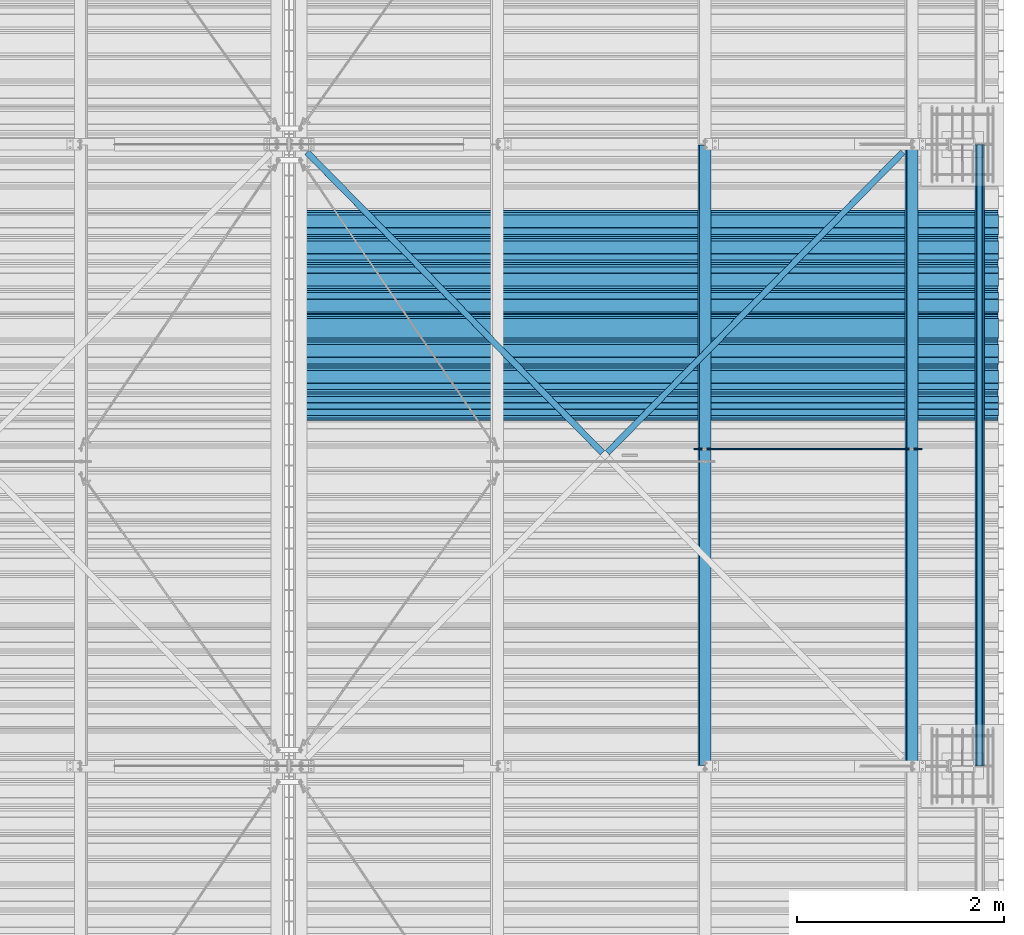
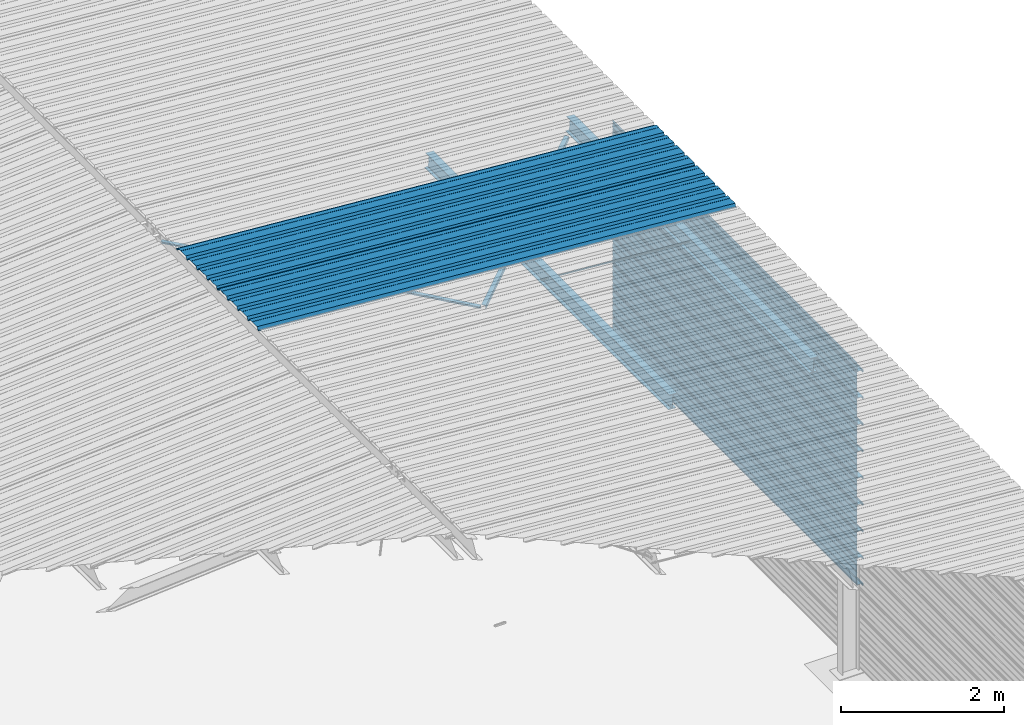
# One storey, part 13 of 70: 16 beams, 16 elements without a shape of their own.
"""IFC2X3 building model written with IfcOpenShell, lengths in millimetres."""

import ifcopenshell
import ifcopenshell.guid

model = None  # the IFC model being written
_history = None  # IfcOwnerHistory: only IFC2X3 demands one
_inside = {}  # id of a spatial element -> (the spatial element, [elements in it])
_under = {}  # id of a project, library or spatial element -> (it, [spatial elements below it])
_declared = {}  # id of a project -> (the project, [libraries it declares])
_typed = {}  # id of a type object -> (the type object, [elements of that type])
_made_of = {}  # id of a material, layer set ... -> (it, [elements and type objects made of it])


def new_model(schema):
    """Start an empty IFC model of exactly this schema.

    Asked for "IFC4X3", IfcOpenShell would pick the latest addendum, in which some entities
    have other attributes; the version numbers below select the first issue.
    IFC2X3 requires an IfcOwnerHistory on every rooted entity: one is made here for all.
    """
    global model, _history
    if schema == "IFC4X3":
        model = ifcopenshell.file(schema_version=(4, 3, 0, 0))
    else:
        model = ifcopenshell.file(schema=schema)
    _inside.clear()
    _under.clear()
    _declared.clear()
    _typed.clear()
    _made_of.clear()
    _history = None
    if model.schema == "IFC2X3":
        org = make("IfcOrganization", Name="unknown")
        user = make(
            "IfcPersonAndOrganization",
            ThePerson=make("IfcPerson", FamilyName="unknown"),
            TheOrganization=org,
        )
        app = make(
            "IfcApplication",
            ApplicationDeveloper=org,
            Version="unknown",
            ApplicationFullName="unknown",
            ApplicationIdentifier="unknown",
        )
        _history = make(
            "IfcOwnerHistory",
            OwningUser=user,
            OwningApplication=app,
            ChangeAction="ADDED",
            CreationDate=0,
        )
    return model


def make(cls, **values):
    """One entity of the class cls with the attributes given. An attribute that is None is left unset."""
    return model.create_entity(
        cls, **{name: value for name, value in values.items() if value is not None}
    )


def rooted(cls, **values):
    """An entity with a GlobalId (a new one), such as an element, a storey or a relation."""
    return make(cls, GlobalId=ifcopenshell.guid.new(), OwnerHistory=_history, **values)


def si_unit(unit_type, name, prefix=None):
    """IfcSIUnit, for example si_unit("LENGTHUNIT", "METRE", prefix="MILLI")."""
    return make("IfcSIUnit", UnitType=unit_type, Prefix=prefix, Name=name)


def assignment(units):
    """IfcUnitAssignment: the units of a project."""
    return None if units is None else make("IfcUnitAssignment", Units=units)


def point(xyz):
    """IfcCartesianPoint."""
    return None if xyz is None else make("IfcCartesianPoint", Coordinates=xyz)


def direction(xyz):
    """IfcDirection."""
    return None if xyz is None else make("IfcDirection", DirectionRatios=xyz)


def frame(location, z_axis=None, x_axis=None):
    """IfcAxis2Placement3D, a coordinate frame: its origin and axes. An axis left out is left unset."""
    return make(
        "IfcAxis2Placement3D",
        Location=point(location),
        Axis=direction(z_axis),
        RefDirection=direction(x_axis),
    )


def frame_2d(location, x_axis=None):
    """IfcAxis2Placement2D, a coordinate frame in the plane: its origin and x axis."""
    return make(
        "IfcAxis2Placement2D", Location=point(location), RefDirection=direction(x_axis)
    )


def origin_with_axes():
    """The frame at (0, 0, 0) with the z axis (0, 0, 1) and the x axis (1, 0, 0) written out."""
    return frame((0.0, 0.0, 0.0), z_axis=(0.0, 0.0, 1.0), x_axis=(1.0, 0.0, 0.0))


def origin_2d_with_axis():
    """The frame at (0, 0) in the plane with the x axis (1, 0) written out."""
    return frame_2d((0.0, 0.0), x_axis=(1.0, 0.0))


def place(relative_to, where):
    """IfcLocalPlacement: puts the frame where relative to a parent placement (None: the world)."""
    return make(
        "IfcLocalPlacement", PlacementRelTo=relative_to, RelativePlacement=where
    )


def context(
    kind, dimensions, precision=None, world=None, true_north=None, identifier=None
):
    """IfcGeometricRepresentationContext, for example the 3D "Model" context."""
    return make(
        "IfcGeometricRepresentationContext",
        ContextIdentifier=identifier,
        ContextType=kind,
        CoordinateSpaceDimension=dimensions,
        Precision=precision,
        WorldCoordinateSystem=world,
        TrueNorth=true_north,
    )


def subcontext(parent, identifier, kind, view, scale=None):
    """IfcGeometricRepresentationSubContext, for example "Body" below "Model"."""
    return make(
        "IfcGeometricRepresentationSubContext",
        ContextIdentifier=identifier,
        ContextType=kind,
        ParentContext=parent,
        TargetScale=scale,
        TargetView=view,
    )


def project(units=None, contexts=None):
    """IfcProject with its units and contexts."""
    return rooted(
        "IfcProject",
        Name="project",
        RepresentationContexts=contexts,
        UnitsInContext=assignment(units),
    )


def spatial(cls, under=None, at=None, **own):
    """A site, building, storey or space (cls), placed at a placement, below another one or the project."""
    s = rooted(cls, ObjectPlacement=at, **own)
    if under is not None:
        _under.setdefault(under.id(), (under, []))[1].append(s)
    return s


def polyline(points):
    """IfcPolyline through the points."""
    return make("IfcPolyline", Points=[point(p) for p in points])


def profile(cls, at=None, kind="AREA", **sizes):
    """A parametric profile (cls). Its sizes go by their IFC names, for example OverallWidth=200.0."""
    return make(cls, ProfileType=kind, Position=at, **sizes)


def circle(**sizes):
    """IfcCircleProfileDef."""
    return profile("IfcCircleProfileDef", **sizes)


def i_section(**sizes):
    """IfcIShapeProfileDef."""
    return profile("IfcIShapeProfileDef", **sizes)


def l_section(**sizes):
    """IfcLShapeProfileDef."""
    return profile("IfcLShapeProfileDef", **sizes)


def outline(outer, holes=None, kind="AREA"):
    """IfcArbitraryClosedProfileDef: a profile drawn as a closed curve; with holes, ...WithVoids."""
    if holes is None:
        return make("IfcArbitraryClosedProfileDef", ProfileType=kind, OuterCurve=outer)
    return make(
        "IfcArbitraryProfileDefWithVoids",
        ProfileType=kind,
        OuterCurve=outer,
        InnerCurves=holes,
    )


def extrude(swept, where, along, depth):
    """IfcExtrudedAreaSolid: the profile swept, set in the frame where, extruded along a direction by depth."""
    return make(
        "IfcExtrudedAreaSolid",
        SweptArea=swept,
        Position=where,
        ExtrudedDirection=direction(along),
        Depth=depth,
    )


def clip(a, b, op="DIFFERENCE"):
    """IfcBooleanClippingResult: the solid a cut by the half space b."""
    return make(
        "IfcBooleanClippingResult", Operator=op, FirstOperand=a, SecondOperand=b
    )


def halfspace(plane, agree):
    """IfcHalfSpaceSolid: all space on one side of the plane z = 0 of the frame plane."""
    return make(
        "IfcHalfSpaceSolid",
        BaseSurface=make("IfcPlane", Position=plane),
        AgreementFlag=agree,
    )


def shape(context_of_items, identifier, shape_type, items):
    """IfcShapeRepresentation: the items that make up one representation, for example the "Body"."""
    return make(
        "IfcShapeRepresentation",
        ContextOfItems=context_of_items,
        RepresentationIdentifier=identifier,
        RepresentationType=shape_type,
        Items=items,
    )


def material(Name=None, Category=None):
    """IfcMaterial."""
    return make("IfcMaterial", Name=Name, Category=Category)


def made_of(thing, what):
    """Note that an element or type object is made of a material, layer set ...; save() writes the relation."""
    if what is not None:
        _made_of.setdefault(what.id(), (what, []))[1].append(thing)
    return thing


def type_object(cls, material=None, **own):
    """A type object (cls), such as IfcWallType, which elements share."""
    return made_of(rooted(cls, **own), material)


def element(
    cls,
    number,
    at=None,
    inside=None,
    cuts=None,
    type_object=None,
    material=None,
    context=None,
    identifier="Body",
    shape_type=None,
    held_by="IfcProductDefinitionShape",
    body=None,
    shapes=None,
    **own,
):
    """One element of the class cls, such as IfcWall. Its Tag is "e" and its number.

    at: its placement. inside: the storey or other place that contains it. cuts: it is an
    opening in that element (IfcRelVoidsElement). A single representation is given by context,
    identifier, shape_type and body (its items); several are given by shapes. held_by: the class
    of the entity that holds the representations. save() writes the other relations.
    """
    e = rooted(cls, Tag="e%d" % number, ObjectPlacement=at, **own)
    if body is not None:
        shapes = [shape(context, identifier, shape_type, body)]
    if shapes is not None:
        e.Representation = make(held_by, Representations=shapes)
    if inside is not None:
        _inside.setdefault(inside.id(), (inside, []))[1].append(e)
    if cuts is not None:
        rooted(
            "IfcRelVoidsElement", RelatingBuildingElement=cuts, RelatedOpeningElement=e
        )
    if type_object is not None:
        _typed.setdefault(type_object.id(), (type_object, []))[1].append(e)
    return made_of(e, material)


def aggregate(whole, parts):
    """IfcRelAggregates: a whole, such as a stair, and the parts it consists of."""
    return rooted("IfcRelAggregates", RelatingObject=whole, RelatedObjects=parts)


def save(model, path):
    """Write the relations noted so far, then the file.

    IfcRelAggregates (storeys below a building ...), IfcRelContainedInSpatialStructure (elements
    in a storey), IfcRelDefinesByType, IfcRelAssociatesMaterial and IfcRelDeclares: one each for
    every whole, place, type object, material and project.
    """
    for whole, parts in _under.values():
        aggregate(whole, parts)
    for where, things in _inside.values():
        rooted(
            "IfcRelContainedInSpatialStructure",
            RelatedElements=things,
            RelatingStructure=where,
        )
    for kind, things in _typed.values():
        rooted("IfcRelDefinesByType", RelatedObjects=things, RelatingType=kind)
    for what, things in _made_of.values():
        rooted("IfcRelAssociatesMaterial", RelatedObjects=things, RelatingMaterial=what)
    for by, libraries in _declared.values():
        rooted("IfcRelDeclares", RelatingContext=by, RelatedDefinitions=libraries)
    model.write(path)


model = new_model("IFC2X3")

# Units and contexts
model_context = context("Model", 3, precision=1e-05, world=origin_with_axes())
body_context = subcontext(model_context, "Body", "Model", "MODEL_VIEW")
ifc_project = project(units=[si_unit("LENGTHUNIT", "METRE", prefix="MILLI"), si_unit("AREAUNIT", "SQUARE_METRE"), si_unit("VOLUMEUNIT", "CUBIC_METRE"), si_unit("MASSUNIT", "GRAM", prefix="KILO"), si_unit("TIMEUNIT", "SECOND"), si_unit("PLANEANGLEUNIT", "RADIAN"), si_unit("SOLIDANGLEUNIT", "STERADIAN"), si_unit("THERMODYNAMICTEMPERATUREUNIT", "DEGREE_CELSIUS"), si_unit("LUMINOUSINTENSITYUNIT", "LUMEN")], contexts=[model_context])

# Site, building, storey
site_placement = place(None, origin_with_axes())
site = spatial("IfcSite", under=ifc_project, at=site_placement, CompositionType="ELEMENT")
building_placement = place(site_placement, origin_with_axes())
building = spatial("IfcBuilding", under=site, at=building_placement, Name="Undefined", CompositionType="ELEMENT")
storey_placement = place(building_placement, origin_with_axes())
storey = spatial("IfcBuildingStorey", under=building, at=storey_placement, Name="Undefined", CompositionType="ELEMENT", Elevation=0.0)

# Assembly, beam
assembly_1_placement = place(storey_placement, origin_with_axes())
assembly_1 = element("IfcElementAssembly", 1, at=assembly_1_placement, inside=storey, Name="Steel Assembly", AssemblyPlace="NOTDEFINED", PredefinedType="RIGID_FRAME")
ifc_material = material(Name="STEEL/S235JR")
beam_type_1 = type_object("IfcBeamType", Name="4.40", PredefinedType="NOTDEFINED")
beam_1_placement = place(assembly_1_placement, frame((6563.60751131961, 9850.00000000015, 5336.31760454378), z_axis=(-0.0766964990376782, 0.0, -0.997054485489817), x_axis=(0.997054485489817, 0.0, -0.0766964990376783)))
beam_1 = element("IfcBeam", 2, at=beam_1_placement, type_object=beam_type_1, material=ifc_material, ObjectType="4.40", context=body_context, shape_type="SweptSolid", body=[
    extrude(outline(polyline([(509.415161132813, 19.5000000011705), (490.584838867188, 19.5000000011705), (468.084838867188, -20.4999999988113), (406.585784912109, -20.4999999988113), (404.585784912109, -18.4999999988122), (345.414215087891, -18.4999999988122), (343.414215087891, -20.4999999988113), (281.915161132813, -20.4999999988113), (259.415161132813, 19.5000000011705), (240.584854125977, 19.5000000011705), (218.084854125977, -20.4999999988113), (156.585784912109, -20.4999999988113), (154.585784912109, -18.4999999988122), (95.4142150878906, -18.4999999988122), (93.4142150878906, -20.4999999988113), (31.9151515960693, -20.4999999988113), (9.41515254974365, 19.5000000011705), (-9.41515254974365, 19.5000000011705), (-31.9151515960693, -20.4999999988113), (-93.4142150878906, -20.4999999988113), (-95.4142150878906, -18.4999999988122), (-154.585784912109, -18.4999999988122), (-156.585784912109, -20.4999999988113), (-218.084854125977, -20.4999999988113), (-240.584854125977, 19.5000000011705), (-259.415161132813, 19.5000000011705), (-281.915161132813, -20.4999999988113), (-343.414215087891, -20.4999999988113), (-345.414215087891, -18.4999999988122), (-404.585784912109, -18.4999999988122), (-406.585784912109, -20.4999999988113), (-468.084838867188, -20.4999999988113), (-490.584838867188, 19.5000000011705), (-509.415161132813, 19.5000000011705), (-516.482360839844, 6.9361057293263), (-517.353942871094, 7.42636680720625), (-510.0, 20.5000000011705), (-490.0, 20.5000000011705), (-467.5, -19.4999999988122), (-407.0, -19.4999999988122), (-405.0, -17.4999999988131), (-345.0, -17.4999999988131), (-343.0, -19.4999999988122), (-282.5, -19.4999999988122), (-260.0, 20.5000000011705), (-240.0, 20.5000000011705), (-217.5, -19.4999999988122), (-157.0, -19.4999999988122), (-155.0, -17.4999999988131), (-95.0, -17.4999999988131), (-93.0, -19.4999999988122), (-32.5, -19.4999999988122), (-10.0, 20.5000000011705), (10.0, 20.5000000011705), (32.5, -19.4999999988122), (93.0, -19.4999999988122), (95.0, -17.4999999988131), (155.0, -17.4999999988131), (157.0, -19.4999999988122), (217.5, -19.4999999988122), (240.0, 20.5000000011705), (260.0, 20.5000000011705), (282.5, -19.4999999988122), (343.0, -19.4999999988122), (345.0, -17.4999999988131), (405.0, -17.4999999988131), (407.0, -19.4999999988122), (467.5, -19.4999999988122), (490.0, 20.5000000011705), (510.0, 20.5000000011705), (517.353942871094, 7.42636680720625), (516.482360839844, 6.9361057293263), (509.415161132813, 19.5000000011705)])), frame((6799.99999999733, 2.8421709430404e-14, 0.0), z_axis=(-1.0, 0.0, 0.0), x_axis=(0.0, -1.0, 0.0)), (0.0, 0.0, 1.0), 6800.0),
])
aggregate(assembly_1, [beam_1])

assembly_2_placement = place(storey_placement, origin_with_axes())
assembly_2 = element("IfcElementAssembly", 3, at=assembly_2_placement, inside=storey, Name="Steel Assembly", AssemblyPlace="NOTDEFINED", PredefinedType="RIGID_FRAME")
beam_2_placement = place(assembly_2_placement, frame((6563.60751131961, 10850.0000000002, 5336.31760454381), z_axis=(-0.0766964990376782, 0.0, -0.997054485489817), x_axis=(0.997054485489817, 0.0, -0.0766964990376783)))
beam_2 = element("IfcBeam", 4, at=beam_2_placement, type_object=beam_type_1, material=ifc_material, ObjectType="4.40", context=body_context, shape_type="SweptSolid", body=[
    extrude(outline(polyline([(509.415161132813, 19.5000000011705), (490.584838867188, 19.5000000011705), (468.084838867188, -20.4999999988113), (406.585784912109, -20.4999999988113), (404.585784912109, -18.4999999988122), (345.414215087891, -18.4999999988122), (343.414215087891, -20.4999999988113), (281.915161132813, -20.4999999988113), (259.415161132813, 19.5000000011705), (240.584854125977, 19.5000000011705), (218.084854125977, -20.4999999988113), (156.585784912109, -20.4999999988113), (154.585784912109, -18.4999999988122), (95.4142150878906, -18.4999999988122), (93.4142150878906, -20.4999999988113), (31.9151515960693, -20.4999999988113), (9.41515254974365, 19.5000000011705), (-9.41515254974365, 19.5000000011705), (-31.9151515960693, -20.4999999988113), (-93.4142150878906, -20.4999999988113), (-95.4142150878906, -18.4999999988122), (-154.585784912109, -18.4999999988122), (-156.585784912109, -20.4999999988113), (-218.084854125977, -20.4999999988113), (-240.584854125977, 19.5000000011705), (-259.415161132813, 19.5000000011705), (-281.915161132813, -20.4999999988113), (-343.414215087891, -20.4999999988113), (-345.414215087891, -18.4999999988122), (-404.585784912109, -18.4999999988122), (-406.585784912109, -20.4999999988113), (-468.084838867188, -20.4999999988113), (-490.584838867188, 19.5000000011705), (-509.415161132813, 19.5000000011705), (-516.482360839844, 6.9361057293263), (-517.353942871094, 7.42636680720625), (-510.0, 20.5000000011705), (-490.0, 20.5000000011705), (-467.5, -19.4999999988122), (-407.0, -19.4999999988122), (-405.0, -17.4999999988131), (-345.0, -17.4999999988131), (-343.0, -19.4999999988122), (-282.5, -19.4999999988122), (-260.0, 20.5000000011705), (-240.0, 20.5000000011705), (-217.5, -19.4999999988122), (-157.0, -19.4999999988122), (-155.0, -17.4999999988131), (-95.0, -17.4999999988131), (-93.0, -19.4999999988122), (-32.5, -19.4999999988122), (-10.0, 20.5000000011705), (10.0, 20.5000000011705), (32.5, -19.4999999988122), (93.0, -19.4999999988122), (95.0, -17.4999999988131), (155.0, -17.4999999988131), (157.0, -19.4999999988122), (217.5, -19.4999999988122), (240.0, 20.5000000011705), (260.0, 20.5000000011705), (282.5, -19.4999999988122), (343.0, -19.4999999988122), (345.0, -17.4999999988131), (405.0, -17.4999999988131), (407.0, -19.4999999988122), (467.5, -19.4999999988122), (490.0, 20.5000000011705), (510.0, 20.5000000011705), (517.353942871094, 7.42636680720625), (516.482360839844, 6.9361057293263), (509.415161132813, 19.5000000011705)])), frame((6799.99999999733, 2.8421709430404e-14, 0.0), z_axis=(-1.0, 0.0, 0.0), x_axis=(0.0, -1.0, 0.0)), (0.0, 0.0, 1.0), 6800.0),
])
aggregate(assembly_2, [beam_2])

assembly_3_placement = place(storey_placement, origin_with_axes())
assembly_3 = element("IfcElementAssembly", 5, at=assembly_3_placement, inside=storey, Name="Steel Assembly", AssemblyPlace="NOTDEFINED", PredefinedType="RIGID_FRAME")
beam_type_2 = type_object("IfcBeamType", Name="400", PredefinedType="NOTDEFINED")
beam_3_placement = place(assembly_3_placement, frame((13165.4999999983, 12000.0, 4618.17396601053), z_axis=(1.0, 0.0, 0.0), x_axis=(0.0, -1.0, 0.0)))
beam_3 = element("IfcBeam", 6, at=beam_3_placement, type_object=beam_type_2, material=ifc_material, ObjectType="400", context=body_context, shape_type="Clipping", body=[
    clip(extrude(outline(polyline([(218.25, -24.994083404541), (214.25, -31.8999996185303), (214.25, -45.5), (199.75, -45.5), (194.25, -42.5), (188.75, -45.5), (124.25, -45.5), (114.25, -41.5), (104.25, -45.5), (24.25, -45.5), (14.25, -41.5), (4.25, -45.5), (-75.75, -45.5), (-85.75, -41.5), (-95.75, -45.5), (-160.25, -45.5), (-165.75, -42.5), (-171.25, -45.5), (-185.75, -45.5), (-185.75, -30.711540222168), (-181.75, -23.8111782073975), (-181.75, 23.311637878418), (-185.75, 30.2119998931885), (-185.75, 44.5), (-217.25, 44.5), (-217.25, 34.7999992370605), (-218.25, 34.7999992370605), (-218.25, 45.5), (-184.75, 45.5), (-184.75, 30.480884552002), (-180.75, 23.5805225372314), (-180.75, -24.0800628662109), (-184.75, -30.9804248809814), (-184.75, -44.5), (-171.504989624023, -44.5), (-165.75, -41.360912322998), (-159.995010375977, -44.5), (-95.9425811767578, -44.5), (-85.75, -40.422966003418), (-75.5574188232422, -44.5), (4.05741739273071, -44.5), (14.25, -40.422966003418), (24.4425830841064, -44.5), (104.057418823242, -44.5), (114.25, -40.422966003418), (124.442581176758, -44.5), (188.495010375977, -44.5), (194.25, -41.360912322998), (200.004989624023, -44.5), (213.25, -44.5), (213.25, -31.6313018798828), (217.25, -24.7253856658936), (217.25, 21.7253856658936), (213.25, 28.6313018798828), (213.25, 42.0), (187.25, 42.0), (187.25, 32.5499992370605), (186.25, 32.5499992370605), (186.25, 43.0), (214.25, 43.0), (214.25, 28.8999996185303), (218.25, 21.994083404541), (218.25, -24.994083404541)])), frame((6000.0, 0.0, 0.0), z_axis=(-1.0, 0.0, 0.0), x_axis=(0.0, -1.0, 0.0)), (0.0, 0.0, 1.0), 6000.0), halfspace(frame((6000.0, 36.6804312648892, -44.9999999999927), z_axis=(0.0, -1.0, 0.0), x_axis=(-1.0, 0.0, 0.0)), False)),
])
aggregate(assembly_3, [beam_3])

assembly_4_placement = place(storey_placement, origin_with_axes())
assembly_4 = element("IfcElementAssembly", 7, at=assembly_4_placement, inside=storey, Name="Steel Assembly", AssemblyPlace="NOTDEFINED", PredefinedType="RIGID_FRAME")
beam_4_placement = place(assembly_4_placement, frame((13165.4999999985, 12000.0, 4218.17396601053), z_axis=(1.0, 0.0, 0.0), x_axis=(0.0, -1.0, 0.0)))
beam_4 = element("IfcBeam", 8, at=beam_4_placement, type_object=beam_type_2, material=ifc_material, ObjectType="400", context=body_context, shape_type="SweptSolid", body=[
    extrude(outline(polyline([(218.25, -24.994083404541), (214.25, -31.8999996185303), (214.25, -45.5), (199.75, -45.5), (194.25, -42.5), (188.75, -45.5), (124.25, -45.5), (114.25, -41.5), (104.25, -45.5), (24.25, -45.5), (14.25, -41.5), (4.25, -45.5), (-75.75, -45.5), (-85.75, -41.5), (-95.75, -45.5), (-160.25, -45.5), (-165.75, -42.5), (-171.25, -45.5), (-185.75, -45.5), (-185.75, -30.711540222168), (-181.75, -23.8111782073975), (-181.75, 23.311637878418), (-185.75, 30.2119998931885), (-185.75, 44.5), (-217.25, 44.5), (-217.25, 34.7999992370605), (-218.25, 34.7999992370605), (-218.25, 45.5), (-184.75, 45.5), (-184.75, 30.480884552002), (-180.75, 23.5805225372314), (-180.75, -24.0800628662109), (-184.75, -30.9804248809814), (-184.75, -44.5), (-171.504989624023, -44.5), (-165.75, -41.360912322998), (-159.995010375977, -44.5), (-95.9425811767578, -44.5), (-85.75, -40.422966003418), (-75.5574188232422, -44.5), (4.05741739273071, -44.5), (14.25, -40.422966003418), (24.4425830841064, -44.5), (104.057418823242, -44.5), (114.25, -40.422966003418), (124.442581176758, -44.5), (188.495010375977, -44.5), (194.25, -41.360912322998), (200.004989624023, -44.5), (213.25, -44.5), (213.25, -31.6313018798828), (217.25, -24.7253856658936), (217.25, 21.7253856658936), (213.25, 28.6313018798828), (213.25, 42.0), (187.25, 42.0), (187.25, 32.5499992370605), (186.25, 32.5499992370605), (186.25, 43.0), (214.25, 43.0), (214.25, 28.8999996185303), (218.25, 21.994083404541), (218.25, -24.994083404541)])), frame((6000.0, 0.0, 0.0), z_axis=(-1.0, 0.0, 0.0), x_axis=(0.0, -1.0, 0.0)), (0.0, 0.0, 1.0), 6000.0),
])
aggregate(assembly_4, [beam_4])

assembly_5_placement = place(storey_placement, origin_with_axes())
assembly_5 = element("IfcElementAssembly", 9, at=assembly_5_placement, inside=storey, Name="Steel Assembly", AssemblyPlace="NOTDEFINED", PredefinedType="RIGID_FRAME")
beam_5_placement = place(assembly_5_placement, frame((13165.4999999986, 12000.0, 3818.17396601053), z_axis=(1.0, 0.0, 0.0), x_axis=(0.0, -1.0, 0.0)))
beam_5 = element("IfcBeam", 10, at=beam_5_placement, type_object=beam_type_2, material=ifc_material, ObjectType="400", context=body_context, shape_type="SweptSolid", body=[
    extrude(outline(polyline([(218.25, -24.994083404541), (214.25, -31.8999996185303), (214.25, -45.5), (199.75, -45.5), (194.25, -42.5), (188.75, -45.5), (124.25, -45.5), (114.25, -41.5), (104.25, -45.5), (24.25, -45.5), (14.25, -41.5), (4.25, -45.5), (-75.75, -45.5), (-85.75, -41.5), (-95.75, -45.5), (-160.25, -45.5), (-165.75, -42.5), (-171.25, -45.5), (-185.75, -45.5), (-185.75, -30.711540222168), (-181.75, -23.8111782073975), (-181.75, 23.311637878418), (-185.75, 30.2119998931885), (-185.75, 44.5), (-217.25, 44.5), (-217.25, 34.7999992370605), (-218.25, 34.7999992370605), (-218.25, 45.5), (-184.75, 45.5), (-184.75, 30.480884552002), (-180.75, 23.5805225372314), (-180.75, -24.0800628662109), (-184.75, -30.9804248809814), (-184.75, -44.5), (-171.504989624023, -44.5), (-165.75, -41.360912322998), (-159.995010375977, -44.5), (-95.9425811767578, -44.5), (-85.75, -40.422966003418), (-75.5574188232422, -44.5), (4.05741739273071, -44.5), (14.25, -40.422966003418), (24.4425830841064, -44.5), (104.057418823242, -44.5), (114.25, -40.422966003418), (124.442581176758, -44.5), (188.495010375977, -44.5), (194.25, -41.360912322998), (200.004989624023, -44.5), (213.25, -44.5), (213.25, -31.6313018798828), (217.25, -24.7253856658936), (217.25, 21.7253856658936), (213.25, 28.6313018798828), (213.25, 42.0), (187.25, 42.0), (187.25, 32.5499992370605), (186.25, 32.5499992370605), (186.25, 43.0), (214.25, 43.0), (214.25, 28.8999996185303), (218.25, 21.994083404541), (218.25, -24.994083404541)])), frame((6000.0, 0.0, 0.0), z_axis=(-1.0, 0.0, 0.0), x_axis=(0.0, -1.0, 0.0)), (0.0, 0.0, 1.0), 6000.0),
])
aggregate(assembly_5, [beam_5])

assembly_6_placement = place(storey_placement, origin_with_axes())
assembly_6 = element("IfcElementAssembly", 11, at=assembly_6_placement, inside=storey, Name="Steel Assembly", AssemblyPlace="NOTDEFINED", PredefinedType="RIGID_FRAME")
beam_6_placement = place(assembly_6_placement, frame((13165.4999999988, 12000.0, 3418.17396601053), z_axis=(1.0, 0.0, 0.0), x_axis=(0.0, -1.0, 0.0)))
beam_6 = element("IfcBeam", 12, at=beam_6_placement, type_object=beam_type_2, material=ifc_material, ObjectType="400", context=body_context, shape_type="SweptSolid", body=[
    extrude(outline(polyline([(218.25, -24.994083404541), (214.25, -31.8999996185303), (214.25, -45.5), (199.75, -45.5), (194.25, -42.5), (188.75, -45.5), (124.25, -45.5), (114.25, -41.5), (104.25, -45.5), (24.25, -45.5), (14.25, -41.5), (4.25, -45.5), (-75.75, -45.5), (-85.75, -41.5), (-95.75, -45.5), (-160.25, -45.5), (-165.75, -42.5), (-171.25, -45.5), (-185.75, -45.5), (-185.75, -30.711540222168), (-181.75, -23.8111782073975), (-181.75, 23.311637878418), (-185.75, 30.2119998931885), (-185.75, 44.5), (-217.25, 44.5), (-217.25, 34.7999992370605), (-218.25, 34.7999992370605), (-218.25, 45.5), (-184.75, 45.5), (-184.75, 30.480884552002), (-180.75, 23.5805225372314), (-180.75, -24.0800628662109), (-184.75, -30.9804248809814), (-184.75, -44.5), (-171.504989624023, -44.5), (-165.75, -41.360912322998), (-159.995010375977, -44.5), (-95.9425811767578, -44.5), (-85.75, -40.422966003418), (-75.5574188232422, -44.5), (4.05741739273071, -44.5), (14.25, -40.422966003418), (24.4425830841064, -44.5), (104.057418823242, -44.5), (114.25, -40.422966003418), (124.442581176758, -44.5), (188.495010375977, -44.5), (194.25, -41.360912322998), (200.004989624023, -44.5), (213.25, -44.5), (213.25, -31.6313018798828), (217.25, -24.7253856658936), (217.25, 21.7253856658936), (213.25, 28.6313018798828), (213.25, 42.0), (187.25, 42.0), (187.25, 32.5499992370605), (186.25, 32.5499992370605), (186.25, 43.0), (214.25, 43.0), (214.25, 28.8999996185303), (218.25, 21.994083404541), (218.25, -24.994083404541)])), frame((6000.0, 0.0, 0.0), z_axis=(-1.0, 0.0, 0.0), x_axis=(0.0, -1.0, 0.0)), (0.0, 0.0, 1.0), 6000.0),
])
aggregate(assembly_6, [beam_6])

assembly_7_placement = place(storey_placement, origin_with_axes())
assembly_7 = element("IfcElementAssembly", 13, at=assembly_7_placement, inside=storey, Name="Steel Assembly", AssemblyPlace="NOTDEFINED", PredefinedType="RIGID_FRAME")
beam_7_placement = place(assembly_7_placement, frame((13165.4999999989, 12000.0, 3018.17396601053), z_axis=(1.0, 0.0, 0.0), x_axis=(0.0, -1.0, 0.0)))
beam_7 = element("IfcBeam", 14, at=beam_7_placement, type_object=beam_type_2, material=ifc_material, ObjectType="400", context=body_context, shape_type="SweptSolid", body=[
    extrude(outline(polyline([(218.25, -24.994083404541), (214.25, -31.8999996185303), (214.25, -45.5), (199.75, -45.5), (194.25, -42.5), (188.75, -45.5), (124.25, -45.5), (114.25, -41.5), (104.25, -45.5), (24.25, -45.5), (14.25, -41.5), (4.25, -45.5), (-75.75, -45.5), (-85.75, -41.5), (-95.75, -45.5), (-160.25, -45.5), (-165.75, -42.5), (-171.25, -45.5), (-185.75, -45.5), (-185.75, -30.711540222168), (-181.75, -23.8111782073975), (-181.75, 23.311637878418), (-185.75, 30.2119998931885), (-185.75, 44.5), (-217.25, 44.5), (-217.25, 34.7999992370605), (-218.25, 34.7999992370605), (-218.25, 45.5), (-184.75, 45.5), (-184.75, 30.480884552002), (-180.75, 23.5805225372314), (-180.75, -24.0800628662109), (-184.75, -30.9804248809814), (-184.75, -44.5), (-171.504989624023, -44.5), (-165.75, -41.360912322998), (-159.995010375977, -44.5), (-95.9425811767578, -44.5), (-85.75, -40.422966003418), (-75.5574188232422, -44.5), (4.05741739273071, -44.5), (14.25, -40.422966003418), (24.4425830841064, -44.5), (104.057418823242, -44.5), (114.25, -40.422966003418), (124.442581176758, -44.5), (188.495010375977, -44.5), (194.25, -41.360912322998), (200.004989624023, -44.5), (213.25, -44.5), (213.25, -31.6313018798828), (217.25, -24.7253856658936), (217.25, 21.7253856658936), (213.25, 28.6313018798828), (213.25, 42.0), (187.25, 42.0), (187.25, 32.5499992370605), (186.25, 32.5499992370605), (186.25, 43.0), (214.25, 43.0), (214.25, 28.8999996185303), (218.25, 21.994083404541), (218.25, -24.994083404541)])), frame((6000.0, 0.0, 0.0), z_axis=(-1.0, 0.0, 0.0), x_axis=(0.0, -1.0, 0.0)), (0.0, 0.0, 1.0), 6000.0),
])
aggregate(assembly_7, [beam_7])

assembly_8_placement = place(storey_placement, origin_with_axes())
assembly_8 = element("IfcElementAssembly", 15, at=assembly_8_placement, inside=storey, Name="Steel Assembly", AssemblyPlace="NOTDEFINED", PredefinedType="RIGID_FRAME")
beam_8_placement = place(assembly_8_placement, frame((13165.4999999991, 12000.0, 2618.17396601053), z_axis=(1.0, 0.0, 0.0), x_axis=(0.0, -1.0, 0.0)))
beam_8 = element("IfcBeam", 16, at=beam_8_placement, type_object=beam_type_2, material=ifc_material, ObjectType="400", context=body_context, shape_type="SweptSolid", body=[
    extrude(outline(polyline([(218.25, -24.994083404541), (214.25, -31.8999996185303), (214.25, -45.5), (199.75, -45.5), (194.25, -42.5), (188.75, -45.5), (124.25, -45.5), (114.25, -41.5), (104.25, -45.5), (24.25, -45.5), (14.25, -41.5), (4.25, -45.5), (-75.75, -45.5), (-85.75, -41.5), (-95.75, -45.5), (-160.25, -45.5), (-165.75, -42.5), (-171.25, -45.5), (-185.75, -45.5), (-185.75, -30.711540222168), (-181.75, -23.8111782073975), (-181.75, 23.311637878418), (-185.75, 30.2119998931885), (-185.75, 44.5), (-217.25, 44.5), (-217.25, 34.7999992370605), (-218.25, 34.7999992370605), (-218.25, 45.5), (-184.75, 45.5), (-184.75, 30.480884552002), (-180.75, 23.5805225372314), (-180.75, -24.0800628662109), (-184.75, -30.9804248809814), (-184.75, -44.5), (-171.504989624023, -44.5), (-165.75, -41.360912322998), (-159.995010375977, -44.5), (-95.9425811767578, -44.5), (-85.75, -40.422966003418), (-75.5574188232422, -44.5), (4.05741739273071, -44.5), (14.25, -40.422966003418), (24.4425830841064, -44.5), (104.057418823242, -44.5), (114.25, -40.422966003418), (124.442581176758, -44.5), (188.495010375977, -44.5), (194.25, -41.360912322998), (200.004989624023, -44.5), (213.25, -44.5), (213.25, -31.6313018798828), (217.25, -24.7253856658936), (217.25, 21.7253856658936), (213.25, 28.6313018798828), (213.25, 42.0), (187.25, 42.0), (187.25, 32.5499992370605), (186.25, 32.5499992370605), (186.25, 43.0), (214.25, 43.0), (214.25, 28.8999996185303), (218.25, 21.994083404541), (218.25, -24.994083404541)])), frame((6000.0, 0.0, 0.0), z_axis=(-1.0, 0.0, 0.0), x_axis=(0.0, -1.0, 0.0)), (0.0, 0.0, 1.0), 6000.0),
])
aggregate(assembly_8, [beam_8])

assembly_9_placement = place(storey_placement, origin_with_axes())
assembly_9 = element("IfcElementAssembly", 17, at=assembly_9_placement, inside=storey, Name="Steel Assembly", AssemblyPlace="NOTDEFINED", PredefinedType="RIGID_FRAME")
beam_9_placement = place(assembly_9_placement, frame((13165.4999999992, 12000.0, 2218.17396601053), z_axis=(1.0, 0.0, 0.0), x_axis=(0.0, -1.0, 0.0)))
beam_9 = element("IfcBeam", 18, at=beam_9_placement, type_object=beam_type_2, material=ifc_material, ObjectType="400", context=body_context, shape_type="SweptSolid", body=[
    extrude(outline(polyline([(218.25, -24.994083404541), (214.25, -31.8999996185303), (214.25, -45.5), (199.75, -45.5), (194.25, -42.5), (188.75, -45.5), (124.25, -45.5), (114.25, -41.5), (104.25, -45.5), (24.25, -45.5), (14.25, -41.5), (4.25, -45.5), (-75.75, -45.5), (-85.75, -41.5), (-95.75, -45.5), (-160.25, -45.5), (-165.75, -42.5), (-171.25, -45.5), (-185.75, -45.5), (-185.75, -30.711540222168), (-181.75, -23.8111782073975), (-181.75, 23.311637878418), (-185.75, 30.2119998931885), (-185.75, 44.5), (-217.25, 44.5), (-217.25, 34.7999992370605), (-218.25, 34.7999992370605), (-218.25, 45.5), (-184.75, 45.5), (-184.75, 30.480884552002), (-180.75, 23.5805225372314), (-180.75, -24.0800628662109), (-184.75, -30.9804248809814), (-184.75, -44.5), (-171.504989624023, -44.5), (-165.75, -41.360912322998), (-159.995010375977, -44.5), (-95.9425811767578, -44.5), (-85.75, -40.422966003418), (-75.5574188232422, -44.5), (4.05741739273071, -44.5), (14.25, -40.422966003418), (24.4425830841064, -44.5), (104.057418823242, -44.5), (114.25, -40.422966003418), (124.442581176758, -44.5), (188.495010375977, -44.5), (194.25, -41.360912322998), (200.004989624023, -44.5), (213.25, -44.5), (213.25, -31.6313018798828), (217.25, -24.7253856658936), (217.25, 21.7253856658936), (213.25, 28.6313018798828), (213.25, 42.0), (187.25, 42.0), (187.25, 32.5499992370605), (186.25, 32.5499992370605), (186.25, 43.0), (214.25, 43.0), (214.25, 28.8999996185303), (218.25, 21.994083404541), (218.25, -24.994083404541)])), frame((6000.0, 0.0, 0.0), z_axis=(-1.0, 0.0, 0.0), x_axis=(0.0, -1.0, 0.0)), (0.0, 0.0, 1.0), 6000.0),
])
aggregate(assembly_9, [beam_9])

assembly_10_placement = place(storey_placement, origin_with_axes())
assembly_10 = element("IfcElementAssembly", 19, at=assembly_10_placement, inside=storey, Name="Steel Assembly", AssemblyPlace="NOTDEFINED", PredefinedType="RIGID_FRAME")
beam_10_placement = place(assembly_10_placement, frame((13165.4999999994, 12000.0, 1818.17396601053), z_axis=(1.0, 0.0, 0.0), x_axis=(0.0, -1.0, 0.0)))
beam_10 = element("IfcBeam", 20, at=beam_10_placement, type_object=beam_type_2, material=ifc_material, ObjectType="400", context=body_context, shape_type="SweptSolid", body=[
    extrude(outline(polyline([(218.25, -24.994083404541), (214.25, -31.8999996185303), (214.25, -45.5), (199.75, -45.5), (194.25, -42.5), (188.75, -45.5), (124.25, -45.5), (114.25, -41.5), (104.25, -45.5), (24.25, -45.5), (14.25, -41.5), (4.25, -45.5), (-75.75, -45.5), (-85.75, -41.5), (-95.75, -45.5), (-160.25, -45.5), (-165.75, -42.5), (-171.25, -45.5), (-185.75, -45.5), (-185.75, -30.711540222168), (-181.75, -23.8111782073975), (-181.75, 23.311637878418), (-185.75, 30.2119998931885), (-185.75, 44.5), (-217.25, 44.5), (-217.25, 34.7999992370605), (-218.25, 34.7999992370605), (-218.25, 45.5), (-184.75, 45.5), (-184.75, 30.480884552002), (-180.75, 23.5805225372314), (-180.75, -24.0800628662109), (-184.75, -30.9804248809814), (-184.75, -44.5), (-171.504989624023, -44.5), (-165.75, -41.360912322998), (-159.995010375977, -44.5), (-95.9425811767578, -44.5), (-85.75, -40.422966003418), (-75.5574188232422, -44.5), (4.05741739273071, -44.5), (14.25, -40.422966003418), (24.4425830841064, -44.5), (104.057418823242, -44.5), (114.25, -40.422966003418), (124.442581176758, -44.5), (188.495010375977, -44.5), (194.25, -41.360912322998), (200.004989624023, -44.5), (213.25, -44.5), (213.25, -31.6313018798828), (217.25, -24.7253856658936), (217.25, 21.7253856658936), (213.25, 28.6313018798828), (213.25, 42.0), (187.25, 42.0), (187.25, 32.5499992370605), (186.25, 32.5499992370605), (186.25, 43.0), (214.25, 43.0), (214.25, 28.8999996185303), (218.25, 21.994083404541), (218.25, -24.994083404541)])), frame((6000.0, 0.0, 0.0), z_axis=(-1.0, 0.0, 0.0), x_axis=(0.0, -1.0, 0.0)), (0.0, 0.0, 1.0), 6000.0),
])
aggregate(assembly_10, [beam_10])

assembly_11_placement = place(storey_placement, origin_with_axes())
assembly_11 = element("IfcElementAssembly", 21, at=assembly_11_placement, inside=storey, Name="Steel Assembly", AssemblyPlace="NOTDEFINED", PredefinedType="RIGID_FRAME")
beam_11_placement = place(assembly_11_placement, frame((13165.4999999995, 12000.0, 1418.17396601053), z_axis=(1.0, 0.0, 0.0), x_axis=(0.0, -1.0, 0.0)))
beam_11 = element("IfcBeam", 22, at=beam_11_placement, type_object=beam_type_2, material=ifc_material, ObjectType="400", context=body_context, shape_type="SweptSolid", body=[
    extrude(outline(polyline([(218.25, -24.994083404541), (214.25, -31.8999996185303), (214.25, -45.5), (199.75, -45.5), (194.25, -42.5), (188.75, -45.5), (124.25, -45.5), (114.25, -41.5), (104.25, -45.5), (24.25, -45.5), (14.25, -41.5), (4.25, -45.5), (-75.75, -45.5), (-85.75, -41.5), (-95.75, -45.5), (-160.25, -45.5), (-165.75, -42.5), (-171.25, -45.5), (-185.75, -45.5), (-185.75, -30.711540222168), (-181.75, -23.8111782073975), (-181.75, 23.311637878418), (-185.75, 30.2119998931885), (-185.75, 44.5), (-217.25, 44.5), (-217.25, 34.7999992370605), (-218.25, 34.7999992370605), (-218.25, 45.5), (-184.75, 45.5), (-184.75, 30.480884552002), (-180.75, 23.5805225372314), (-180.75, -24.0800628662109), (-184.75, -30.9804248809814), (-184.75, -44.5), (-171.504989624023, -44.5), (-165.75, -41.360912322998), (-159.995010375977, -44.5), (-95.9425811767578, -44.5), (-85.75, -40.422966003418), (-75.5574188232422, -44.5), (4.05741739273071, -44.5), (14.25, -40.422966003418), (24.4425830841064, -44.5), (104.057418823242, -44.5), (114.25, -40.422966003418), (124.442581176758, -44.5), (188.495010375977, -44.5), (194.25, -41.360912322998), (200.004989624023, -44.5), (213.25, -44.5), (213.25, -31.6313018798828), (217.25, -24.7253856658936), (217.25, 21.7253856658936), (213.25, 28.6313018798828), (213.25, 42.0), (187.25, 42.0), (187.25, 32.5499992370605), (186.25, 32.5499992370605), (186.25, 43.0), (214.25, 43.0), (214.25, 28.8999996185303), (218.25, 21.994083404541), (218.25, -24.994083404541)])), frame((6000.0, 0.0, 0.0), z_axis=(-1.0, 0.0, 0.0), x_axis=(0.0, -1.0, 0.0)), (0.0, 0.0, 1.0), 6000.0),
])
aggregate(assembly_11, [beam_11])

assembly_12_placement = place(storey_placement, origin_with_axes())
assembly_12 = element("IfcElementAssembly", 23, at=assembly_12_placement, inside=storey, Name="Steel Assembly", AssemblyPlace="NOTDEFINED", PredefinedType="RIGID_FRAME")
beam_type_3 = type_object("IfcBeamType", Name="D14", PredefinedType="NOTDEFINED")
beam_12_placement = place(assembly_12_placement, frame((10408.7311663468, 9060.00000000009, 4909.65333500212), z_axis=(-0.0766964990376782, 0.0, -0.997054485489817), x_axis=(0.997054485489817, 0.0, -0.0766964990376783)))
beam_12 = element("IfcBeam", 24, at=beam_12_placement, type_object=beam_type_3, material=ifc_material, Name="THREAD60MM", ObjectType="D14", context=body_context, shape_type="SweptSolid", body=[
    extrude(circle(Radius=7.0, at=origin_2d_with_axis()), frame((2205.90843239298, 9.09494701772928e-13, -9.40107830921147e-13), z_axis=(-1.0, 0.0, 0.0), x_axis=(0.0, -1.0, 0.0)), (0.0, 0.0, 1.0), 2205.91),
])
aggregate(assembly_12, [beam_12])

assembly_13_placement = place(storey_placement, origin_with_axes())
assembly_13 = element("IfcElementAssembly", 25, at=assembly_13_placement, inside=storey, Name="Steel Assembly", AssemblyPlace="NOTDEFINED", PredefinedType="RIGID_FRAME")
beam_type_4 = type_object("IfcBeamType", PredefinedType="NOTDEFINED")
beam_13_placement = place(assembly_13_placement, frame((9524.59459681898, 9021.72508858881, 4819.99943791493), z_axis=(-0.0766964990376782, 0.0, -0.997054485489817), x_axis=(-0.700122412215615, 0.711988894219269, 0.0538555700165858)))
beam_13 = element("IfcBeam", 26, at=beam_13_placement, type_object=beam_type_4, material=ifc_material, Name="POUTRE", context=body_context, shape_type="Clipping", body=[
    clip(extrude(l_section(Depth=60.0, Width=60.0, Thickness=6.0, FilletRadius=8.0, EdgeRadius=4.0, at=origin_2d_with_axis()), frame((4076.20008167735, 2.10890368249889e-12, -5.65686397957142e-14), z_axis=(-1.0, 0.0, 0.0), x_axis=(0.0, -1.0, 0.0)), (0.0, 0.0, 1.0), 4136.91), halfspace(frame((3.465656868581, -29.9999999936408, 7.93625076767057e-09), z_axis=(1.0, 0.0, 0.0), x_axis=(0.0, 0.0, 1.0)), True)),
])
aggregate(assembly_13, [beam_13])

assembly_14_placement = place(storey_placement, origin_with_axes())
assembly_14 = element("IfcElementAssembly", 27, at=assembly_14_placement, inside=storey, Name="Steel Assembly", AssemblyPlace="NOTDEFINED", PredefinedType="RIGID_FRAME")
beam_14_placement = place(assembly_14_placement, frame((9567.43373715526, 9021.8401388673, 4816.70411942035), z_axis=(-0.0766964990376782, 0.0, -0.997054485489817), x_axis=(0.700122412215615, 0.711988894219269, -0.0538555700165857)))
beam_14 = element("IfcBeam", 28, at=beam_14_placement, type_object=beam_type_4, material=ifc_material, Name="POUTRE", context=body_context, shape_type="Clipping", body=[
    clip(extrude(l_section(Depth=60.0, Width=60.0, Thickness=6.0, FilletRadius=8.0, EdgeRadius=4.0, at=origin_2d_with_axis()), frame((4076.03849422642, -4.60954145823837e-13, -9.09494701772928e-13), z_axis=(-1.0, 0.0, 0.0), x_axis=(0.0, -1.0, 0.0)), (0.0, 0.0, 1.0), 4136.91), halfspace(frame((3.30406689240226, -29.9999999944503, -8.59108695294708e-09), z_axis=(1.0, 0.0, 0.0), x_axis=(0.0, 0.0, 1.0)), True)),
])
aggregate(assembly_14, [beam_14])

assembly_15_placement = place(storey_placement, origin_with_axes())
assembly_15 = element("IfcElementAssembly", 29, at=assembly_15_placement, inside=storey, Name="Steel Assembly", AssemblyPlace="NOTDEFINED", PredefinedType="RIGID_FRAME")
beam_type_5 = type_object("IfcBeamType", Name="IPE220", PredefinedType="NOTDEFINED")
beam_15_placement = place(assembly_15_placement, frame((12508.4366148949, 6000.0, 4748.13753094857), z_axis=(0.0766964990376782, 0.0, 0.997054485489817), x_axis=(0.0, 1.0, 0.0)))
beam_15 = element("IfcBeam", 30, at=beam_15_placement, type_object=beam_type_5, material=ifc_material, ObjectType="IPE220", context=body_context, shape_type="Clipping", body=[
    clip(clip(extrude(i_section(OverallWidth=110.0, OverallDepth=220.0, WebThickness=5.900000095, FlangeThickness=9.199999809, FilletRadius=12.0, at=origin_2d_with_axis()), frame((5995.0, 1.81898940354586e-12, 0.0), z_axis=(-1.0, 0.0, 0.0), x_axis=(0.0, -1.0, 0.0)), (0.0, 0.0, 1.0), 5990.0), halfspace(frame((5995.0, 1.81898940354586e-12, 0.0), z_axis=(1.0, 0.0, 0.0), x_axis=(0.0, -1.0, 0.0)), False)), halfspace(frame((4.99999999999636, 7.09405867382884e-11, -1.79170456249267e-10), z_axis=(1.0, 0.0, 0.0), x_axis=(0.0, -1.0, 0.0)), True)),
])
aggregate(assembly_15, [beam_15])

assembly_16_placement = place(storey_placement, origin_with_axes())
assembly_16 = element("IfcElementAssembly", 31, at=assembly_16_placement, inside=storey, Name="Steel Assembly", AssemblyPlace="NOTDEFINED", PredefinedType="RIGID_FRAME")
beam_16_placement = place(assembly_16_placement, frame((10508.4366148949, 6000.0, 4901.98368510388), z_axis=(0.0766964990376782, 0.0, 0.997054485489817), x_axis=(0.0, 1.0, 0.0)))
beam_16 = element("IfcBeam", 32, at=beam_16_placement, type_object=beam_type_5, material=ifc_material, ObjectType="IPE220", context=body_context, shape_type="Clipping", body=[
    clip(clip(extrude(i_section(OverallWidth=110.0, OverallDepth=220.0, WebThickness=5.900000095, FlangeThickness=9.199999809, FilletRadius=12.0, at=origin_2d_with_axis()), frame((5995.0, 1.81898940354586e-12, 0.0), z_axis=(-1.0, 0.0, 0.0), x_axis=(0.0, -1.0, 0.0)), (0.0, 0.0, 1.0), 5990.0), halfspace(frame((5995.0, 1.81898940354586e-12, 0.0), z_axis=(1.0, 0.0, 0.0), x_axis=(0.0, -1.0, 0.0)), False)), halfspace(frame((4.99999999999636, 7.09405867382884e-11, -1.79170456249267e-10), z_axis=(1.0, 0.0, 0.0), x_axis=(0.0, -1.0, 0.0)), True)),
])
aggregate(assembly_16, [beam_16])

save(model, "model.ifc")
